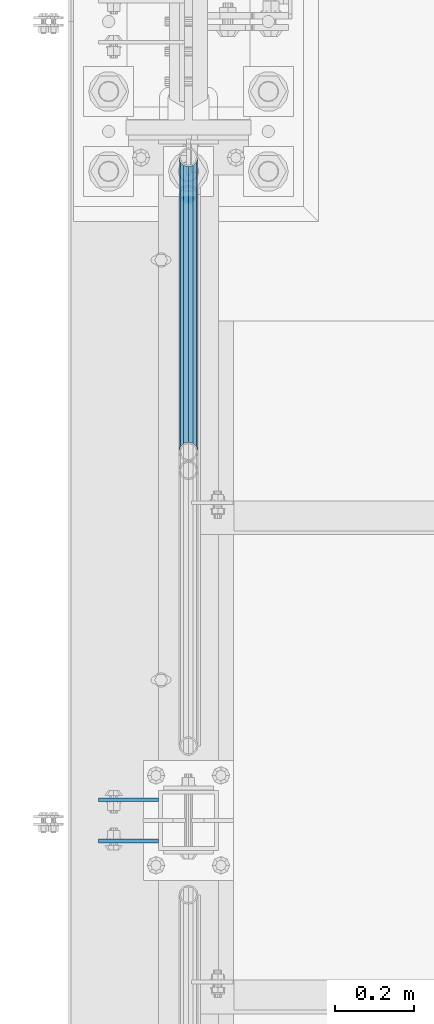
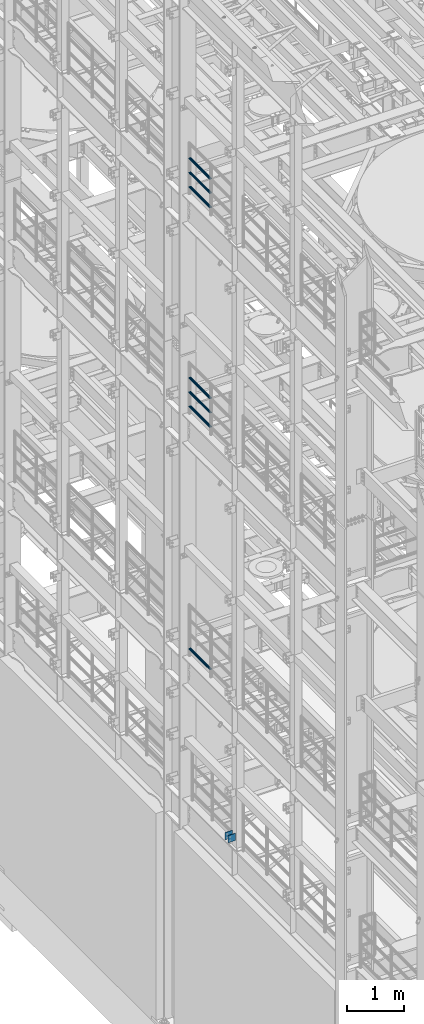
# One storey, part 1233 of 1876: 9 beams, 4 elements without a shape of their own.
"""IFC2X3 building model written with IfcOpenShell, lengths in millimetres."""

from ifc_helpers import new_model, si_unit, frame, origin_with_axes, place, context, subcontext, project, spatial, faceted_brep, material, type_object, element, aggregate, save


model = new_model("IFC2X3")

# Units and contexts
model_context = context("Model", 3, precision=1e-05, world=origin_with_axes())
body_context = subcontext(model_context, "Body", "Model", "MODEL_VIEW")
ifc_project = project(units=[si_unit("LENGTHUNIT", "METRE", prefix="MILLI"), si_unit("AREAUNIT", "SQUARE_METRE"), si_unit("VOLUMEUNIT", "CUBIC_METRE"), si_unit("MASSUNIT", "GRAM", prefix="KILO"), si_unit("TIMEUNIT", "SECOND"), si_unit("PLANEANGLEUNIT", "RADIAN"), si_unit("SOLIDANGLEUNIT", "STERADIAN"), si_unit("THERMODYNAMICTEMPERATUREUNIT", "DEGREE_CELSIUS"), si_unit("LUMINOUSINTENSITYUNIT", "LUMEN")], contexts=[model_context])

# Site, building, storey
site_placement = place(None, origin_with_axes())
site = spatial("IfcSite", under=ifc_project, at=site_placement, CompositionType="ELEMENT")
building_placement = place(site_placement, origin_with_axes())
building = spatial("IfcBuilding", under=site, at=building_placement, Name="Undefined", CompositionType="ELEMENT")
storey_placement = place(building_placement, origin_with_axes())
storey = spatial("IfcBuildingStorey", under=building, at=storey_placement, Name="Undefined", CompositionType="ELEMENT", Elevation=0.0)

# Assembly, beams
assembly_1_placement = place(storey_placement, origin_with_axes())
assembly_1 = element("IfcElementAssembly", 1, at=assembly_1_placement, inside=storey, Name="BEAM", AssemblyPlace="NOTDEFINED", PredefinedType="RIGID_FRAME")
ifc_material_1 = material(Name="STEEL/A36")
beam_type_1 = type_object("IfcBeamType", PredefinedType="NOTDEFINED")
beam_1_placement = place(assembly_1_placement, frame((-76.2, -455.612499999999, 5384.8), z_axis=(0.0, 0.0, -1.0), x_axis=(-1.0, 0.0, 0.0)))
beam_1 = element("IfcBeam", 2, at=beam_1_placement, type_object=beam_type_1, material=ifc_material_1, Name="PLATE", context=body_context, shape_type="Brep", body=[
    faceted_brep([(0.0, 4.76249999999982, -76.1999999999998), (3.63797880709171e-12, 4.76249999999982, 76.1999969482422), (152.399993896484, 4.76250000000073, 76.1999969482422), (152.4, 4.76249999999982, -76.1999999999998), (3.63797880709171e-12, -4.76249999999982, 76.1999969482422), (152.399993896484, -4.76250000000073, 76.1999969482422), (0.0, -4.76249999999982, -76.1999999999998), (152.4, -4.76249999999982, -76.1999999999998)], [[[0, 1, 2, 3]], [[4, 5, 2, 1]], [[4, 6, 7, 5]], [[6, 0, 3, 7]], [[5, 7, 3, 2]], [[6, 4, 1, 0]]]),
])
beam_2_placement = place(assembly_1_placement, frame((-76.2, -560.387500000001, 5384.8), z_axis=(0.0, 0.0, -1.0), x_axis=(-1.0, 0.0, 0.0)))
beam_2 = element("IfcBeam", 3, at=beam_2_placement, type_object=beam_type_1, material=ifc_material_1, Name="PLATE", context=body_context, shape_type="Brep", body=[
    faceted_brep([(0.0, 4.76249999999982, -76.1999999999998), (3.63797880709171e-12, 4.76249999999982, 76.1999969482422), (152.399993896484, 4.76250000000073, 76.1999969482422), (152.4, 4.76249999999982, -76.1999999999998), (3.63797880709171e-12, -4.76249999999982, 76.1999969482422), (152.399993896484, -4.76250000000073, 76.1999969482422), (0.0, -4.76249999999982, -76.1999999999998), (152.4, -4.76249999999982, -76.1999999999998)], [[[0, 1, 2, 3]], [[4, 5, 2, 1]], [[4, 6, 7, 5]], [[6, 0, 3, 7]], [[5, 7, 3, 2]], [[6, 4, 1, 0]]]),
])
aggregate(assembly_1, [beam_1, beam_2])

assembly_2_placement = place(storey_placement, origin_with_axes())
assembly_2 = element("IfcElementAssembly", 4, at=assembly_2_placement, inside=storey, Name="RAIL", AssemblyPlace="NOTDEFINED", PredefinedType="RIGID_FRAME")
ifc_material_2 = material()
beam_type_2 = type_object("IfcBeamType", Name="PIPE1-1/2SCH40", PredefinedType="NOTDEFINED")
beam_3_placement = place(assembly_2_placement, frame((-1.14353341410584e-11, 1179.195, 18145.125), z_axis=(0.0, 0.0, 1.0), x_axis=(0.0, -1.0, 0.0)))
beam_3 = element("IfcBeam", 5, at=beam_3_placement, type_object=beam_type_2, material=ifc_material_2, Name="RAIL", ObjectType="PIPE1-1/2SCH40", context=body_context, shape_type="Brep", body=[
    faceted_brep([(728.085307006683, -12.0649999999996, 20.8971929933177), (728.085307006683, -12.0649999999996, 15.8661214311796), (727.591878568821, -10.2235000000001, 17.7076214311819), (724.852500000002, 0.0, 20.4470000000001), (724.852500000002, 0.0, 24.130000000001), (727.591878568821, 10.2235000000001, 17.7076214311819), (728.085307006683, 12.0649999999996, 15.8661214311796), (728.085307006683, 12.0649999999996, 20.8971929933177), (748.982500000002, 24.1300000000001, 0.0), (736.917500000002, 20.8971929933186, 12.0649999999987), (736.917500000002, 20.8971929933186, -12.0649999999987), (733.727928437864, 17.7076214311801, 10.2235000000001), (736.467307006683, 20.4470000000001, 0.0), (733.727928437864, 17.7076214311801, -10.2235000000001), (728.085307006683, 12.0649999999996, -15.8661214311796), (728.085307006683, 12.0649999999996, -20.8971929933177), (727.591878568821, 10.2235000000001, -17.7076214311819), (724.852500000002, 0.0, -20.4470000000001), (724.852500000002, 0.0, -24.130000000001), (728.085307006683, -12.0649999999996, -15.8661214311796), (728.085307006683, -12.0649999999996, -20.8971929933177), (727.591878568821, -10.2235000000001, -17.7076214311819), (748.982500000002, -24.1300000000001, 0.0), (736.917500000002, -20.8971929933186, -12.0649999999987), (736.917500000002, -20.8971929933186, 12.0649999999987), (733.727928437864, -17.7076214311801, -10.2235000000001), (736.467307006683, -20.4470000000001, 0.0), (733.727928437864, -17.7076214311801, 10.2235000000001), (12.0650000000064, -20.8971929933177, -12.0649999999987), (20.8971929933249, -12.0650000000005, -20.8971929933177), (0.0, 24.1299999999992, 0.0), (12.0650000000064, 20.8971929933177, -12.0649999999987), (12.0650000000064, 20.8971929933177, 12.0649999999987), (20.8971929933249, 12.0650000000005, 20.8971929933177), (24.1300000000064, 0.0, 24.130000000001), (20.8971929933249, 12.0650000000005, -20.8971929933177), (24.1300000000063, 0.0, -24.130000000001), (24.1300000000063, 0.0, -20.4470000000001), (20.8971929933249, -12.0650000000005, -15.8661214311796), (21.3906214311868, -10.2235000000001, -17.7076214311819), (21.3906214311868, 10.2235000000001, -17.7076214311819), (20.8971929933249, 12.0650000000005, -15.8661214311796), (15.2545715621445, 17.7076214311801, -10.2235000000001), (12.5151929933249, 20.4470000000001, 0.0), (15.2545715621445, 17.7076214311801, 10.2235000000001), (20.8971929933249, 12.0650000000005, 15.8661214311796), (21.3906214311868, 10.2235000000001, 17.7076214311819), (24.1300000000064, 0.0, 20.4470000000001), (21.3906214311868, -10.2235000000001, 17.7076214311819), (20.8971929933249, -12.0650000000005, 15.8661214311796), (20.8971929933249, -12.0650000000005, 20.8971929933177), (12.0650000000064, -20.8971929933177, 12.0649999999987), (0.0, -24.1299999999992, 0.0), (15.2545715621445, -17.7076214311801, 10.2235000000001), (12.5151929933249, -20.4470000000001, 0.0), (15.2545715621445, -17.7076214311801, -10.2235000000001)], [[[0, 1, 2, 3, 4]], [[4, 3, 5, 6, 7]], [[8, 9, 10]], [[7, 6, 11, 12, 13, 14, 15, 10, 9]], [[16, 17, 18, 15, 14]], [[19, 20, 18, 17, 21]], [[22, 23, 24]], [[24, 23, 20, 19, 25, 26, 27, 1, 0]], [[28, 29, 20, 23]], [[30, 31, 32]], [[33, 34, 4, 7]], [[32, 33, 7, 9]], [[30, 32, 9, 8]], [[31, 30, 8, 10]], [[35, 31, 10, 15]], [[36, 35, 15, 18]], [[29, 36, 18, 20]], [[37, 36, 29, 38, 39]], [[40, 41, 35, 36, 37]], [[32, 31, 35, 41, 42, 43, 44, 45, 33]], [[33, 45, 46, 47, 34]], [[34, 47, 48, 49, 50]], [[34, 50, 0, 4]], [[50, 51, 24, 0]], [[51, 52, 22, 24]], [[52, 28, 23, 22]], [[51, 28, 52]], [[50, 49, 53, 54, 55, 38, 29, 28, 51]], [[55, 54, 26, 25]], [[21, 39, 38, 55, 25, 19]], [[37, 39, 21, 17]], [[40, 37, 17, 16]], [[42, 41, 40, 16, 14, 13]], [[43, 42, 13, 12]], [[44, 43, 12, 11]], [[5, 46, 45, 44, 11, 6]], [[47, 46, 5, 3]], [[48, 47, 3, 2]], [[53, 49, 48, 2, 1, 27]], [[54, 53, 27, 26]]]),
])
beam_4_placement = place(assembly_2_placement, frame((-1.81898940354586e-12, 430.212499999999, 18449.925), z_axis=(0.0, 0.0, -1.0), x_axis=(0.0, 1.0, 0.0)))
beam_4 = element("IfcBeam", 6, at=beam_4_placement, type_object=beam_type_2, material=ifc_material_2, Name="RAIL", ObjectType="PIPE1-1/2SCH40", context=body_context, shape_type="Brep", body=[
    faceted_brep([(0.0, 24.1299999999992, 0.0), (12.0650000000064, 20.8971929933177, -12.0649999999987), (12.0650000000064, 20.8971929933177, 12.0649999999987), (12.0650000000064, -20.8971929933177, 12.0649999999987), (12.0650000000064, -20.8971929933177, -12.0649999999987), (0.0, -24.1299999999992, 0.0), (20.8971929933249, -12.0650000000005, 20.8971929933177), (20.8971929933249, -12.0650000000005, 15.8661214311796), (15.2545715621445, -17.7076214311801, 10.2235000000001), (12.5151929933249, -20.4470000000001, 0.0), (15.2545715621445, -17.7076214311801, -10.2235000000001), (20.8971929933249, -12.0650000000005, -15.8661214311796), (20.8971929933249, -12.0650000000005, -20.8971929933177), (24.1300000000063, 0.0, -20.4470000000001), (24.1300000000063, 0.0, -24.130000000001), (21.3906214311868, -10.2235000000001, -17.7076214311819), (21.3906214311868, 10.2235000000001, -17.7076214311819), (20.8971929933249, 12.0650000000005, -15.8661214311796), (20.8971929933249, 12.0650000000005, -20.8971929933177), (15.2545715621445, 17.7076214311801, -10.2235000000001), (12.5151929933249, 20.4470000000001, 0.0), (15.2545715621445, 17.7076214311801, 10.2235000000001), (20.8971929933249, 12.0650000000005, 15.8661214311796), (20.8971929933249, 12.0650000000005, 20.8971929933177), (21.3906214311868, 10.2235000000001, 17.7076214311819), (24.1300000000064, 0.0, 20.4470000000001), (24.1300000000064, 0.0, 24.130000000001), (21.3906214311868, -10.2235000000001, 17.7076214311819), (748.982500000002, 24.1300000000001, 0.0), (736.917500000002, 20.8971929933186, -12.0649999999987), (728.085307006683, 12.0649999999996, -20.8971929933177), (748.982500000002, -24.1300000000001, 0.0), (736.917500000002, -20.8971929933186, -12.0649999999987), (736.917500000002, -20.8971929933186, 12.0649999999987), (728.085307006683, -12.0649999999996, 20.8971929933177), (728.085307006683, -12.0649999999996, -20.8971929933177), (724.852500000002, 0.0, -24.130000000001), (727.591878568821, 10.2235000000001, -17.7076214311819), (724.852500000002, 0.0, -20.4470000000001), (728.085307006683, 12.0649999999996, -15.8661214311796), (728.085307006683, -12.0649999999996, -15.8661214311796), (727.591878568821, -10.2235000000001, -17.7076214311819), (733.727928437864, -17.7076214311801, -10.2235000000001), (736.467307006683, -20.4470000000001, 0.0), (733.727928437864, -17.7076214311801, 10.2235000000001), (728.085307006683, -12.0649999999996, 15.8661214311796), (727.591878568821, -10.2235000000001, 17.7076214311819), (724.852500000002, 0.0, 20.4470000000001), (724.852500000002, 0.0, 24.130000000001), (728.085307006683, 12.0649999999996, 20.8971929933177), (736.917500000002, 20.8971929933186, 12.0649999999987), (728.085307006683, 12.0649999999996, 15.8661214311796), (733.727928437864, 17.7076214311801, 10.2235000000001), (736.467307006683, 20.4470000000001, 0.0), (733.727928437864, 17.7076214311801, -10.2235000000001), (727.591878568821, 10.2235000000001, 17.7076214311819)], [[[0, 1, 2]], [[3, 4, 5]], [[6, 7, 8, 9, 10, 11, 12, 4, 3]], [[13, 14, 12, 11, 15]], [[16, 17, 18, 14, 13]], [[2, 1, 18, 17, 19, 20, 21, 22, 23]], [[23, 22, 24, 25, 26]], [[26, 25, 27, 7, 6]], [[1, 0, 28, 29]], [[18, 1, 29, 30]], [[31, 32, 33]], [[6, 3, 33, 34]], [[3, 5, 31, 33]], [[5, 4, 32, 31]], [[4, 12, 35, 32]], [[12, 14, 36, 35]], [[14, 18, 30, 36]], [[37, 38, 36, 30, 39]], [[40, 35, 36, 38, 41]], [[33, 32, 35, 40, 42, 43, 44, 45, 34]], [[34, 45, 46, 47, 48]], [[26, 6, 34, 48]], [[2, 23, 49, 50]], [[23, 26, 48, 49]], [[0, 2, 50, 28]], [[28, 50, 29]], [[49, 51, 52, 53, 54, 39, 30, 29, 50]], [[48, 47, 55, 51, 49]], [[25, 24, 55, 47]], [[55, 24, 22, 21, 52, 51]], [[21, 20, 53, 52]], [[20, 19, 54, 53]], [[19, 17, 16, 37, 39, 54]], [[16, 13, 38, 37]], [[13, 15, 41, 38]], [[41, 15, 11, 10, 42, 40]], [[10, 9, 43, 42]], [[9, 8, 44, 43]], [[8, 7, 27, 46, 45, 44]], [[27, 25, 47, 46]]]),
])
beam_5_placement = place(assembly_2_placement, frame((-1.81898940354586e-12, 430.212499999999, 18754.725), z_axis=(0.0, 0.0, -1.0), x_axis=(0.0, 1.0, 0.0)))
beam_5 = element("IfcBeam", 7, at=beam_5_placement, type_object=beam_type_2, material=ifc_material_2, Name="RAIL", ObjectType="PIPE1-1/2SCH40", context=body_context, shape_type="Brep", body=[
    faceted_brep([(0.0, 24.1299999999992, 0.0), (12.0650000000064, 20.8971929933177, -12.0649999999987), (12.0650000000064, 20.8971929933177, 12.0649999999987), (12.0650000000064, -20.8971929933177, 12.0649999999987), (12.0650000000064, -20.8971929933177, -12.0649999999987), (0.0, -24.1299999999992, 0.0), (20.8971929933249, -12.0650000000005, 20.8971929933177), (20.8971929933249, -12.0650000000005, 15.8661214311796), (15.2545715621445, -17.7076214311801, 10.2235000000001), (12.5151929933249, -20.4470000000001, 0.0), (15.2545715621445, -17.7076214311801, -10.2235000000001), (20.8971929933249, -12.0650000000005, -15.8661214311796), (20.8971929933249, -12.0650000000005, -20.8971929933177), (24.1300000000063, 0.0, -20.4470000000001), (24.1300000000063, 0.0, -24.130000000001), (21.3906214311868, -10.2235000000001, -17.7076214311819), (21.3906214311868, 10.2235000000001, -17.7076214311819), (20.8971929933249, 12.0650000000005, -15.8661214311796), (20.8971929933249, 12.0650000000005, -20.8971929933177), (15.2545715621445, 17.7076214311801, -10.2235000000001), (12.5151929933249, 20.4470000000001, 0.0), (15.2545715621445, 17.7076214311801, 10.2235000000001), (20.8971929933249, 12.0650000000005, 15.8661214311796), (20.8971929933249, 12.0650000000005, 20.8971929933177), (21.3906214311868, 10.2235000000001, 17.7076214311819), (24.1300000000064, 0.0, 20.4470000000001), (24.1300000000064, 0.0, 24.130000000001), (21.3906214311868, -10.2235000000001, 17.7076214311819), (748.982500000002, 24.1300000000001, 0.0), (736.917500000002, 20.8971929933186, -12.0649999999987), (728.085307006683, 12.0649999999996, -20.8971929933177), (748.982500000002, -24.1300000000001, 0.0), (736.917500000002, -20.8971929933186, -12.0649999999987), (736.917500000002, -20.8971929933186, 12.0649999999987), (728.085307006683, -12.0649999999996, 20.8971929933177), (728.085307006683, -12.0649999999996, -20.8971929933177), (724.852500000002, 0.0, -24.130000000001), (727.591878568821, 10.2235000000001, -17.7076214311819), (724.852500000002, 0.0, -20.4470000000001), (728.085307006683, 12.0649999999996, -15.8661214311796), (728.085307006683, -12.0649999999996, -15.8661214311796), (727.591878568821, -10.2235000000001, -17.7076214311819), (733.727928437864, -17.7076214311801, -10.2235000000001), (736.467307006683, -20.4470000000001, 0.0), (733.727928437864, -17.7076214311801, 10.2235000000001), (728.085307006683, -12.0649999999996, 15.8661214311796), (727.591878568821, -10.2235000000001, 17.7076214311819), (724.852500000002, 0.0, 20.4470000000001), (724.852500000002, 0.0, 24.130000000001), (728.085307006683, 12.0649999999996, 20.8971929933177), (736.917500000002, 20.8971929933186, 12.0649999999987), (728.085307006683, 12.0649999999996, 15.8661214311796), (733.727928437864, 17.7076214311801, 10.2235000000001), (736.467307006683, 20.4470000000001, 0.0), (733.727928437864, 17.7076214311801, -10.2235000000001), (727.591878568821, 10.2235000000001, 17.7076214311819)], [[[0, 1, 2]], [[3, 4, 5]], [[6, 7, 8, 9, 10, 11, 12, 4, 3]], [[13, 14, 12, 11, 15]], [[16, 17, 18, 14, 13]], [[2, 1, 18, 17, 19, 20, 21, 22, 23]], [[23, 22, 24, 25, 26]], [[26, 25, 27, 7, 6]], [[1, 0, 28, 29]], [[18, 1, 29, 30]], [[31, 32, 33]], [[6, 3, 33, 34]], [[3, 5, 31, 33]], [[5, 4, 32, 31]], [[4, 12, 35, 32]], [[12, 14, 36, 35]], [[14, 18, 30, 36]], [[37, 38, 36, 30, 39]], [[40, 35, 36, 38, 41]], [[33, 32, 35, 40, 42, 43, 44, 45, 34]], [[34, 45, 46, 47, 48]], [[26, 6, 34, 48]], [[2, 23, 49, 50]], [[23, 26, 48, 49]], [[0, 2, 50, 28]], [[28, 50, 29]], [[49, 51, 52, 53, 54, 39, 30, 29, 50]], [[48, 47, 55, 51, 49]], [[25, 24, 55, 47]], [[55, 24, 22, 21, 52, 51]], [[21, 20, 53, 52]], [[20, 19, 54, 53]], [[19, 17, 16, 37, 39, 54]], [[16, 13, 38, 37]], [[13, 15, 41, 38]], [[41, 15, 11, 10, 42, 40]], [[10, 9, 43, 42]], [[9, 8, 44, 43]], [[8, 7, 27, 46, 45, 44]], [[27, 25, 47, 46]]]),
])
aggregate(assembly_2, [beam_3, beam_4, beam_5])

assembly_3_placement = place(storey_placement, origin_with_axes())
assembly_3 = element("IfcElementAssembly", 8, at=assembly_3_placement, inside=storey, Name="RAIL", AssemblyPlace="NOTDEFINED", PredefinedType="RIGID_FRAME")
beam_6_placement = place(assembly_3_placement, frame((-1.14353341410584e-11, 1179.195, 13471.525), z_axis=(0.0, 0.0, 1.0), x_axis=(0.0, -1.0, 0.0)))
beam_6 = element("IfcBeam", 9, at=beam_6_placement, type_object=beam_type_2, material=ifc_material_2, Name="RAIL", ObjectType="PIPE1-1/2SCH40", context=body_context, shape_type="Brep", body=[
    faceted_brep([(728.085307006683, -12.0649999999996, 20.8971929933177), (728.085307006683, -12.0649999999996, 15.8661214311796), (727.591878568821, -10.2235000000001, 17.7076214311819), (724.852500000002, 0.0, 20.4470000000001), (724.852500000002, 0.0, 24.130000000001), (727.591878568821, 10.2235000000001, 17.7076214311819), (728.085307006683, 12.0649999999996, 15.8661214311796), (728.085307006683, 12.0649999999996, 20.8971929933177), (748.982500000002, 24.1300000000001, 0.0), (736.917500000002, 20.8971929933186, 12.0649999999987), (736.917500000002, 20.8971929933186, -12.0649999999987), (733.727928437864, 17.7076214311801, 10.2235000000001), (736.467307006683, 20.4470000000001, 0.0), (733.727928437864, 17.7076214311801, -10.2235000000001), (728.085307006683, 12.0649999999996, -15.8661214311796), (728.085307006683, 12.0649999999996, -20.8971929933177), (727.591878568821, 10.2235000000001, -17.7076214311819), (724.852500000002, 0.0, -20.4470000000001), (724.852500000002, 0.0, -24.130000000001), (728.085307006683, -12.0649999999996, -15.8661214311796), (728.085307006683, -12.0649999999996, -20.8971929933177), (727.591878568821, -10.2235000000001, -17.7076214311819), (748.982500000002, -24.1300000000001, 0.0), (736.917500000002, -20.8971929933186, -12.0649999999987), (736.917500000002, -20.8971929933186, 12.0649999999987), (733.727928437864, -17.7076214311801, -10.2235000000001), (736.467307006683, -20.4470000000001, 0.0), (733.727928437864, -17.7076214311801, 10.2235000000001), (12.0650000000064, -20.8971929933177, -12.0649999999987), (20.8971929933249, -12.0650000000005, -20.8971929933177), (0.0, 24.1299999999992, 0.0), (12.0650000000064, 20.8971929933177, -12.0649999999987), (12.0650000000064, 20.8971929933177, 12.0649999999987), (20.8971929933249, 12.0650000000005, 20.8971929933177), (24.1300000000064, 0.0, 24.130000000001), (20.8971929933249, 12.0650000000005, -20.8971929933177), (24.1300000000063, 0.0, -24.130000000001), (24.1300000000063, 0.0, -20.4470000000001), (20.8971929933249, -12.0650000000005, -15.8661214311796), (21.3906214311868, -10.2235000000001, -17.7076214311819), (21.3906214311868, 10.2235000000001, -17.7076214311819), (20.8971929933249, 12.0650000000005, -15.8661214311796), (15.2545715621445, 17.7076214311801, -10.2235000000001), (12.5151929933249, 20.4470000000001, 0.0), (15.2545715621445, 17.7076214311801, 10.2235000000001), (20.8971929933249, 12.0650000000005, 15.8661214311796), (21.3906214311868, 10.2235000000001, 17.7076214311819), (24.1300000000064, 0.0, 20.4470000000001), (21.3906214311868, -10.2235000000001, 17.7076214311819), (20.8971929933249, -12.0650000000005, 15.8661214311796), (20.8971929933249, -12.0650000000005, 20.8971929933177), (12.0650000000064, -20.8971929933177, 12.0649999999987), (0.0, -24.1299999999992, 0.0), (15.2545715621445, -17.7076214311801, 10.2235000000001), (12.5151929933249, -20.4470000000001, 0.0), (15.2545715621445, -17.7076214311801, -10.2235000000001)], [[[0, 1, 2, 3, 4]], [[4, 3, 5, 6, 7]], [[8, 9, 10]], [[7, 6, 11, 12, 13, 14, 15, 10, 9]], [[16, 17, 18, 15, 14]], [[19, 20, 18, 17, 21]], [[22, 23, 24]], [[24, 23, 20, 19, 25, 26, 27, 1, 0]], [[28, 29, 20, 23]], [[30, 31, 32]], [[33, 34, 4, 7]], [[32, 33, 7, 9]], [[30, 32, 9, 8]], [[31, 30, 8, 10]], [[35, 31, 10, 15]], [[36, 35, 15, 18]], [[29, 36, 18, 20]], [[37, 36, 29, 38, 39]], [[40, 41, 35, 36, 37]], [[32, 31, 35, 41, 42, 43, 44, 45, 33]], [[33, 45, 46, 47, 34]], [[34, 47, 48, 49, 50]], [[34, 50, 0, 4]], [[50, 51, 24, 0]], [[51, 52, 22, 24]], [[52, 28, 23, 22]], [[51, 28, 52]], [[50, 49, 53, 54, 55, 38, 29, 28, 51]], [[55, 54, 26, 25]], [[21, 39, 38, 55, 25, 19]], [[37, 39, 21, 17]], [[40, 37, 17, 16]], [[42, 41, 40, 16, 14, 13]], [[43, 42, 13, 12]], [[44, 43, 12, 11]], [[5, 46, 45, 44, 11, 6]], [[47, 46, 5, 3]], [[48, 47, 3, 2]], [[53, 49, 48, 2, 1, 27]], [[54, 53, 27, 26]]]),
])
beam_7_placement = place(assembly_3_placement, frame((-1.81898940354586e-12, 430.212499999999, 13776.325), z_axis=(0.0, 0.0, -1.0), x_axis=(0.0, 1.0, 0.0)))
beam_7 = element("IfcBeam", 10, at=beam_7_placement, type_object=beam_type_2, material=ifc_material_2, Name="RAIL", ObjectType="PIPE1-1/2SCH40", context=body_context, shape_type="Brep", body=[
    faceted_brep([(0.0, 24.1299999999992, 0.0), (12.0650000000064, 20.8971929933177, -12.0649999999987), (12.0650000000064, 20.8971929933177, 12.0649999999987), (12.0650000000064, -20.8971929933177, 12.0649999999987), (12.0650000000064, -20.8971929933177, -12.0649999999987), (0.0, -24.1299999999992, 0.0), (20.8971929933249, -12.0650000000005, 20.8971929933177), (20.8971929933249, -12.0650000000005, 15.8661214311796), (15.2545715621445, -17.7076214311801, 10.2235000000001), (12.5151929933249, -20.4470000000001, 0.0), (15.2545715621445, -17.7076214311801, -10.2235000000001), (20.8971929933249, -12.0650000000005, -15.8661214311796), (20.8971929933249, -12.0650000000005, -20.8971929933177), (24.1300000000063, 0.0, -20.4470000000001), (24.1300000000063, 0.0, -24.130000000001), (21.3906214311868, -10.2235000000001, -17.7076214311819), (21.3906214311868, 10.2235000000001, -17.7076214311819), (20.8971929933249, 12.0650000000005, -15.8661214311796), (20.8971929933249, 12.0650000000005, -20.8971929933177), (15.2545715621445, 17.7076214311801, -10.2235000000001), (12.5151929933249, 20.4470000000001, 0.0), (15.2545715621445, 17.7076214311801, 10.2235000000001), (20.8971929933249, 12.0650000000005, 15.8661214311796), (20.8971929933249, 12.0650000000005, 20.8971929933177), (21.3906214311868, 10.2235000000001, 17.7076214311819), (24.1300000000064, 0.0, 20.4470000000001), (24.1300000000064, 0.0, 24.130000000001), (21.3906214311868, -10.2235000000001, 17.7076214311819), (748.982500000002, 24.1300000000001, 0.0), (736.917500000002, 20.8971929933186, -12.0649999999987), (728.085307006683, 12.0649999999996, -20.8971929933177), (748.982500000002, -24.1300000000001, 0.0), (736.917500000002, -20.8971929933186, -12.0649999999987), (736.917500000002, -20.8971929933186, 12.0649999999987), (728.085307006683, -12.0649999999996, 20.8971929933177), (728.085307006683, -12.0649999999996, -20.8971929933177), (724.852500000002, 0.0, -24.130000000001), (727.591878568821, 10.2235000000001, -17.7076214311819), (724.852500000002, 0.0, -20.4470000000001), (728.085307006683, 12.0649999999996, -15.8661214311796), (728.085307006683, -12.0649999999996, -15.8661214311796), (727.591878568821, -10.2235000000001, -17.7076214311819), (733.727928437864, -17.7076214311801, -10.2235000000001), (736.467307006683, -20.4470000000001, 0.0), (733.727928437864, -17.7076214311801, 10.2235000000001), (728.085307006683, -12.0649999999996, 15.8661214311796), (727.591878568821, -10.2235000000001, 17.7076214311819), (724.852500000002, 0.0, 20.4470000000001), (724.852500000002, 0.0, 24.130000000001), (728.085307006683, 12.0649999999996, 20.8971929933177), (736.917500000002, 20.8971929933186, 12.0649999999987), (728.085307006683, 12.0649999999996, 15.8661214311796), (733.727928437864, 17.7076214311801, 10.2235000000001), (736.467307006683, 20.4470000000001, 0.0), (733.727928437864, 17.7076214311801, -10.2235000000001), (727.591878568821, 10.2235000000001, 17.7076214311819)], [[[0, 1, 2]], [[3, 4, 5]], [[6, 7, 8, 9, 10, 11, 12, 4, 3]], [[13, 14, 12, 11, 15]], [[16, 17, 18, 14, 13]], [[2, 1, 18, 17, 19, 20, 21, 22, 23]], [[23, 22, 24, 25, 26]], [[26, 25, 27, 7, 6]], [[1, 0, 28, 29]], [[18, 1, 29, 30]], [[31, 32, 33]], [[6, 3, 33, 34]], [[3, 5, 31, 33]], [[5, 4, 32, 31]], [[4, 12, 35, 32]], [[12, 14, 36, 35]], [[14, 18, 30, 36]], [[37, 38, 36, 30, 39]], [[40, 35, 36, 38, 41]], [[33, 32, 35, 40, 42, 43, 44, 45, 34]], [[34, 45, 46, 47, 48]], [[26, 6, 34, 48]], [[2, 23, 49, 50]], [[23, 26, 48, 49]], [[0, 2, 50, 28]], [[28, 50, 29]], [[49, 51, 52, 53, 54, 39, 30, 29, 50]], [[48, 47, 55, 51, 49]], [[25, 24, 55, 47]], [[55, 24, 22, 21, 52, 51]], [[21, 20, 53, 52]], [[20, 19, 54, 53]], [[19, 17, 16, 37, 39, 54]], [[16, 13, 38, 37]], [[13, 15, 41, 38]], [[41, 15, 11, 10, 42, 40]], [[10, 9, 43, 42]], [[9, 8, 44, 43]], [[8, 7, 27, 46, 45, 44]], [[27, 25, 47, 46]]]),
])
beam_8_placement = place(assembly_3_placement, frame((-1.81898940354586e-12, 430.212499999999, 14081.125), z_axis=(0.0, 0.0, -1.0), x_axis=(0.0, 1.0, 0.0)))
beam_8 = element("IfcBeam", 11, at=beam_8_placement, type_object=beam_type_2, material=ifc_material_2, Name="RAIL", ObjectType="PIPE1-1/2SCH40", context=body_context, shape_type="Brep", body=[
    faceted_brep([(0.0, 24.1299999999992, 0.0), (12.0650000000064, 20.8971929933177, -12.0649999999987), (12.0650000000064, 20.8971929933177, 12.0649999999987), (12.0650000000064, -20.8971929933177, 12.0649999999987), (12.0650000000064, -20.8971929933177, -12.0649999999987), (0.0, -24.1299999999992, 0.0), (20.8971929933249, -12.0650000000005, 20.8971929933177), (20.8971929933249, -12.0650000000005, 15.8661214311796), (15.2545715621445, -17.7076214311801, 10.2235000000001), (12.5151929933249, -20.4470000000001, 0.0), (15.2545715621445, -17.7076214311801, -10.2235000000001), (20.8971929933249, -12.0650000000005, -15.8661214311796), (20.8971929933249, -12.0650000000005, -20.8971929933177), (24.1300000000063, 0.0, -20.4470000000001), (24.1300000000063, 0.0, -24.130000000001), (21.3906214311868, -10.2235000000001, -17.7076214311819), (21.3906214311868, 10.2235000000001, -17.7076214311819), (20.8971929933249, 12.0650000000005, -15.8661214311796), (20.8971929933249, 12.0650000000005, -20.8971929933177), (15.2545715621445, 17.7076214311801, -10.2235000000001), (12.5151929933249, 20.4470000000001, 0.0), (15.2545715621445, 17.7076214311801, 10.2235000000001), (20.8971929933249, 12.0650000000005, 15.8661214311796), (20.8971929933249, 12.0650000000005, 20.8971929933177), (21.3906214311868, 10.2235000000001, 17.7076214311819), (24.1300000000064, 0.0, 20.4470000000001), (24.1300000000064, 0.0, 24.130000000001), (21.3906214311868, -10.2235000000001, 17.7076214311819), (748.982500000002, 24.1300000000001, 0.0), (736.917500000002, 20.8971929933186, -12.0649999999987), (728.085307006683, 12.0649999999996, -20.8971929933177), (748.982500000002, -24.1300000000001, 0.0), (736.917500000002, -20.8971929933186, -12.0649999999987), (736.917500000002, -20.8971929933186, 12.0649999999987), (728.085307006683, -12.0649999999996, 20.8971929933177), (728.085307006683, -12.0649999999996, -20.8971929933177), (724.852500000002, 0.0, -24.130000000001), (727.591878568821, 10.2235000000001, -17.7076214311819), (724.852500000002, 0.0, -20.4470000000001), (728.085307006683, 12.0649999999996, -15.8661214311796), (728.085307006683, -12.0649999999996, -15.8661214311796), (727.591878568821, -10.2235000000001, -17.7076214311819), (733.727928437864, -17.7076214311801, -10.2235000000001), (736.467307006683, -20.4470000000001, 0.0), (733.727928437864, -17.7076214311801, 10.2235000000001), (728.085307006683, -12.0649999999996, 15.8661214311796), (727.591878568821, -10.2235000000001, 17.7076214311819), (724.852500000002, 0.0, 20.4470000000001), (724.852500000002, 0.0, 24.130000000001), (728.085307006683, 12.0649999999996, 20.8971929933177), (736.917500000002, 20.8971929933186, 12.0649999999987), (728.085307006683, 12.0649999999996, 15.8661214311796), (733.727928437864, 17.7076214311801, 10.2235000000001), (736.467307006683, 20.4470000000001, 0.0), (733.727928437864, 17.7076214311801, -10.2235000000001), (727.591878568821, 10.2235000000001, 17.7076214311819)], [[[0, 1, 2]], [[3, 4, 5]], [[6, 7, 8, 9, 10, 11, 12, 4, 3]], [[13, 14, 12, 11, 15]], [[16, 17, 18, 14, 13]], [[2, 1, 18, 17, 19, 20, 21, 22, 23]], [[23, 22, 24, 25, 26]], [[26, 25, 27, 7, 6]], [[1, 0, 28, 29]], [[18, 1, 29, 30]], [[31, 32, 33]], [[6, 3, 33, 34]], [[3, 5, 31, 33]], [[5, 4, 32, 31]], [[4, 12, 35, 32]], [[12, 14, 36, 35]], [[14, 18, 30, 36]], [[37, 38, 36, 30, 39]], [[40, 35, 36, 38, 41]], [[33, 32, 35, 40, 42, 43, 44, 45, 34]], [[34, 45, 46, 47, 48]], [[26, 6, 34, 48]], [[2, 23, 49, 50]], [[23, 26, 48, 49]], [[0, 2, 50, 28]], [[28, 50, 29]], [[49, 51, 52, 53, 54, 39, 30, 29, 50]], [[48, 47, 55, 51, 49]], [[25, 24, 55, 47]], [[55, 24, 22, 21, 52, 51]], [[21, 20, 53, 52]], [[20, 19, 54, 53]], [[19, 17, 16, 37, 39, 54]], [[16, 13, 38, 37]], [[13, 15, 41, 38]], [[41, 15, 11, 10, 42, 40]], [[10, 9, 43, 42]], [[9, 8, 44, 43]], [[8, 7, 27, 46, 45, 44]], [[27, 25, 47, 46]]]),
])
aggregate(assembly_3, [beam_6, beam_7, beam_8])

# Assembly, beam
assembly_4_placement = place(storey_placement, origin_with_axes())
assembly_4 = element("IfcElementAssembly", 12, at=assembly_4_placement, inside=storey, Name="RAIL", AssemblyPlace="NOTDEFINED", PredefinedType="RIGID_FRAME")
beam_9_placement = place(assembly_4_placement, frame((-1.14353341410584e-11, 1179.195, 8315.325), z_axis=(0.0, 0.0, 1.0), x_axis=(0.0, -1.0, 0.0)))
beam_9 = element("IfcBeam", 13, at=beam_9_placement, type_object=beam_type_2, material=ifc_material_2, Name="RAIL", ObjectType="PIPE1-1/2SCH40", context=body_context, shape_type="Brep", body=[
    faceted_brep([(728.085307006683, -12.0649999999996, 20.8971929933177), (728.085307006683, -12.0649999999996, 15.8661214311796), (727.591878568821, -10.2235000000001, 17.7076214311819), (724.852500000002, 0.0, 20.4470000000001), (724.852500000002, 0.0, 24.130000000001), (727.591878568821, 10.2235000000001, 17.7076214311819), (728.085307006683, 12.0649999999996, 15.8661214311796), (728.085307006683, 12.0649999999996, 20.8971929933177), (748.982500000002, 24.1300000000001, 0.0), (736.917500000002, 20.8971929933186, 12.0649999999987), (736.917500000002, 20.8971929933186, -12.0649999999987), (733.727928437864, 17.7076214311801, 10.2235000000001), (736.467307006683, 20.4470000000001, 0.0), (733.727928437864, 17.7076214311801, -10.2235000000001), (728.085307006683, 12.0649999999996, -15.8661214311796), (728.085307006683, 12.0649999999996, -20.8971929933177), (727.591878568821, 10.2235000000001, -17.7076214311819), (724.852500000002, 0.0, -20.4470000000001), (724.852500000002, 0.0, -24.130000000001), (728.085307006683, -12.0649999999996, -15.8661214311796), (728.085307006683, -12.0649999999996, -20.8971929933177), (727.591878568821, -10.2235000000001, -17.7076214311819), (748.982500000002, -24.1300000000001, 0.0), (736.917500000002, -20.8971929933186, -12.0649999999987), (736.917500000002, -20.8971929933186, 12.0649999999987), (733.727928437864, -17.7076214311801, -10.2235000000001), (736.467307006683, -20.4470000000001, 0.0), (733.727928437864, -17.7076214311801, 10.2235000000001), (12.0650000000064, -20.8971929933177, -12.0649999999987), (20.8971929933249, -12.0650000000005, -20.8971929933177), (0.0, 24.1299999999992, 0.0), (12.0650000000064, 20.8971929933177, -12.0649999999987), (12.0650000000064, 20.8971929933177, 12.0649999999987), (20.8971929933249, 12.0650000000005, 20.8971929933177), (24.1300000000064, 0.0, 24.130000000001), (20.8971929933249, 12.0650000000005, -20.8971929933177), (24.1300000000063, 0.0, -24.130000000001), (24.1300000000063, 0.0, -20.4470000000001), (20.8971929933249, -12.0650000000005, -15.8661214311796), (21.3906214311868, -10.2235000000001, -17.7076214311819), (21.3906214311868, 10.2235000000001, -17.7076214311819), (20.8971929933249, 12.0650000000005, -15.8661214311796), (15.2545715621445, 17.7076214311801, -10.2235000000001), (12.5151929933249, 20.4470000000001, 0.0), (15.2545715621445, 17.7076214311801, 10.2235000000001), (20.8971929933249, 12.0650000000005, 15.8661214311796), (21.3906214311868, 10.2235000000001, 17.7076214311819), (24.1300000000064, 0.0, 20.4470000000001), (21.3906214311868, -10.2235000000001, 17.7076214311819), (20.8971929933249, -12.0650000000005, 15.8661214311796), (20.8971929933249, -12.0650000000005, 20.8971929933177), (12.0650000000064, -20.8971929933177, 12.0649999999987), (0.0, -24.1299999999992, 0.0), (15.2545715621445, -17.7076214311801, 10.2235000000001), (12.5151929933249, -20.4470000000001, 0.0), (15.2545715621445, -17.7076214311801, -10.2235000000001)], [[[0, 1, 2, 3, 4]], [[4, 3, 5, 6, 7]], [[8, 9, 10]], [[7, 6, 11, 12, 13, 14, 15, 10, 9]], [[16, 17, 18, 15, 14]], [[19, 20, 18, 17, 21]], [[22, 23, 24]], [[24, 23, 20, 19, 25, 26, 27, 1, 0]], [[28, 29, 20, 23]], [[30, 31, 32]], [[33, 34, 4, 7]], [[32, 33, 7, 9]], [[30, 32, 9, 8]], [[31, 30, 8, 10]], [[35, 31, 10, 15]], [[36, 35, 15, 18]], [[29, 36, 18, 20]], [[37, 36, 29, 38, 39]], [[40, 41, 35, 36, 37]], [[32, 31, 35, 41, 42, 43, 44, 45, 33]], [[33, 45, 46, 47, 34]], [[34, 47, 48, 49, 50]], [[34, 50, 0, 4]], [[50, 51, 24, 0]], [[51, 52, 22, 24]], [[52, 28, 23, 22]], [[51, 28, 52]], [[50, 49, 53, 54, 55, 38, 29, 28, 51]], [[55, 54, 26, 25]], [[21, 39, 38, 55, 25, 19]], [[37, 39, 21, 17]], [[40, 37, 17, 16]], [[42, 41, 40, 16, 14, 13]], [[43, 42, 13, 12]], [[44, 43, 12, 11]], [[5, 46, 45, 44, 11, 6]], [[47, 46, 5, 3]], [[48, 47, 3, 2]], [[53, 49, 48, 2, 1, 27]], [[54, 53, 27, 26]]]),
])
aggregate(assembly_4, [beam_9])

save(model, "model.ifc")
